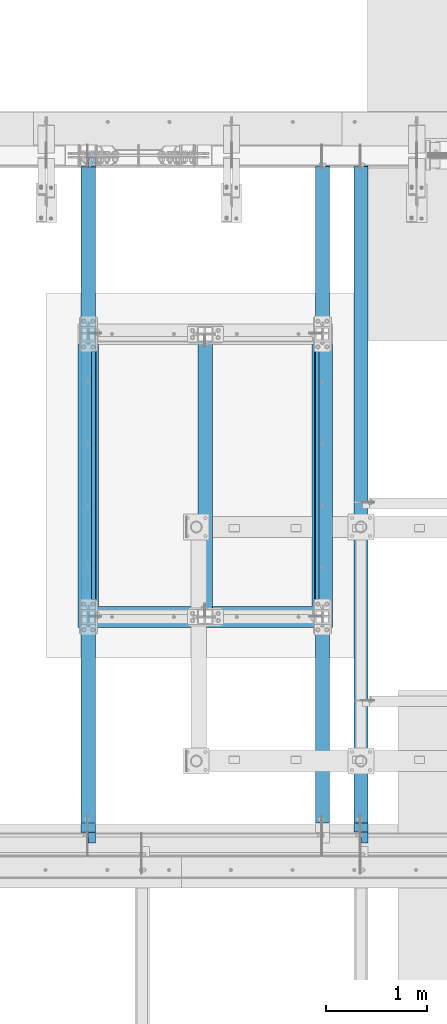
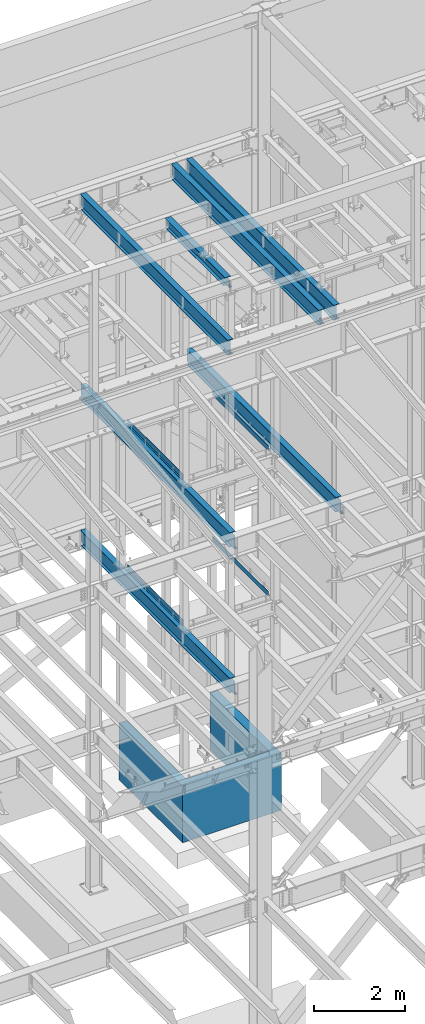
# One storey, part 772 of 1179: 12 beams, 10 elements without a shape of their own.
"""IFC2X3 building model written with IfcOpenShell, lengths in millimetres."""

from ifc_helpers import new_model, si_unit, frame, origin_with_axes, place, context, subcontext, project, spatial, faceted_brep, material, type_object, element, aggregate, save


model = new_model("IFC2X3")

# Units and contexts
model_context = context("Model", 3, precision=1e-05, world=origin_with_axes())
body_context = subcontext(model_context, "Body", "Model", "MODEL_VIEW")
ifc_project = project(units=[si_unit("LENGTHUNIT", "METRE", prefix="MILLI"), si_unit("AREAUNIT", "SQUARE_METRE"), si_unit("VOLUMEUNIT", "CUBIC_METRE"), si_unit("MASSUNIT", "GRAM", prefix="KILO"), si_unit("TIMEUNIT", "SECOND"), si_unit("PLANEANGLEUNIT", "RADIAN"), si_unit("SOLIDANGLEUNIT", "STERADIAN"), si_unit("THERMODYNAMICTEMPERATUREUNIT", "DEGREE_CELSIUS"), si_unit("LUMINOUSINTENSITYUNIT", "LUMEN")], contexts=[model_context])

# Site, building, storey
site_placement = place(None, origin_with_axes())
site = spatial("IfcSite", under=ifc_project, at=site_placement, CompositionType="ELEMENT")
building_placement = place(site_placement, origin_with_axes())
building = spatial("IfcBuilding", under=site, at=building_placement, Name="Undefined", CompositionType="ELEMENT")
storey_placement = place(building_placement, origin_with_axes())
storey = spatial("IfcBuildingStorey", under=building, at=storey_placement, Name="Undefined", CompositionType="ELEMENT", Elevation=0.0)

# Assembly, beam
assembly_1_placement = place(storey_placement, origin_with_axes())
assembly_1 = element("IfcElementAssembly", 1, at=assembly_1_placement, inside=storey, Name="BEAM", AssemblyPlace="NOTDEFINED", PredefinedType="RIGID_FRAME")
ifc_material_1 = material(Name="STEEL/A992")
beam_type_1 = type_object("IfcBeamType", Name="W10X22", PredefinedType="NOTDEFINED")
beam_1_placement = place(assembly_1_placement, frame((13030.2, 36639.5, 12990.5125), z_axis=(0.0, 0.0, 1.0), x_axis=(0.0, 1.0, 0.0)))
beam_1 = element("IfcBeam", 2, at=beam_1_placement, type_object=beam_type_1, material=ifc_material_1, Name="BEAM", ObjectType="W10X22", context=body_context, shape_type="Brep", body=[
    faceted_brep([(142.875, 3.37346071813408, -119.0625), (142.875, 3.37346071813408, -128.5875), (15.875, 3.37346071813408, -128.5875), (15.875, 3.17499999999927, -119.0625), (142.875001471613, 73.0249999999996, -119.0625), (142.875001471613, 73.0249999999996, -128.5875), (76.1999999999898, 3.17499999999927, 119.0625), (76.1999999999898, 73.0249999999996, 119.0625), (2717.8, 73.0249999999996, 119.0625), (2717.8, 3.17499999999927, 119.0625), (76.1999999999898, -73.0249999999996, 128.5875), (76.1999999999898, 73.0249999999996, 128.5875), (76.1999999999898, 3.17499999999927, 115.887499809265), (76.1999999999898, -3.17499999999927, 115.887499809265), (76.1999999999898, -3.17499999999927, 119.0625), (76.1999999999898, -73.0249999999996, 119.0625), (75.2332700773986, 3.17499999999927, 111.027420291219), (75.2332700773986, -3.17499999999927, 111.027420291219), (72.4802561769247, 3.17499999999927, 106.907243823065), (72.4802561769247, -3.17499999999927, 106.907243823065), (68.3600797087711, 3.17499999999927, 104.154229922588), (68.3600797087711, -3.17499999999927, 104.154229922588), (63.5000001907247, 3.17499999999927, 103.1875), (63.5000001907247, -3.17499999999927, 103.1875), (15.875, 3.17499999999927, 103.1875), (15.875, -3.17499999999927, 103.1875), (15.875, -3.17499999999927, -119.0625), (15.875, -73.0249999999996, -119.0625), (2778.125, -73.0249999999996, -119.0625), (2778.125, -3.17499999999927, -119.0625), (15.875, -73.0249999999996, -128.5875), (2778.125, -73.0249999999996, -128.5875), (2651.12499819296, 3.17499999999927, -119.0625), (2651.12499819296, 3.37346071813408, -128.5875), (2651.12499966458, 73.0249999999996, -128.5875), (2651.12499966458, 73.0249999999996, -119.0625), (2778.125, 3.17499999999927, -119.0625), (2778.125, 3.37346071813408, -128.5875), (2778.125, 3.17499999999927, 12.4375), (2778.125, 3.17499999999927, 103.1875), (2778.125, -3.17499999999927, 103.1875), (2725.63992029122, -3.17499999999927, 104.154229922588), (2721.51974382307, -3.17499999999927, 106.907243823065), (2718.76672992259, -3.17499999999927, 111.027420291219), (2717.8, -3.17499999999927, 115.887499809265), (2717.8, -3.17499999999927, 119.0625), (2730.49999980927, -3.17499999999927, 103.1875), (2717.8, -73.0249999999996, 119.0625), (2717.8, -73.0249999999996, 128.5875), (2717.8, 73.0249999999996, 128.5875), (2717.8, 3.17499999999927, 115.887499809265), (2718.76672992259, 3.17499999999927, 111.027420291219), (2721.51974382307, 3.17499999999927, 106.907243823065), (2725.63992029122, 3.17499999999927, 104.154229922588), (2730.49999980927, 3.17499999999927, 103.1875), (15.875, 3.17499999999927, 12.4375)], [[[0, 1, 2, 3]], [[4, 5, 1, 0]], [[6, 7, 8, 9]], [[10, 11, 7, 6, 12, 13, 14, 15]], [[13, 12, 16, 17]], [[17, 16, 18, 19]], [[19, 18, 20, 21]], [[21, 20, 22, 23]], [[23, 22, 24, 25]], [[26, 27, 28, 29]], [[27, 30, 31, 28]], [[32, 33, 34, 35]], [[36, 37, 33, 32]], [[38, 39, 40, 29, 28, 31, 37, 36]], [[41, 42, 43, 44, 45, 14, 13, 17, 19, 21, 23, 25, 26, 29, 40, 46]], [[15, 14, 45, 47]], [[10, 15, 47, 48]], [[11, 10, 48, 49]], [[7, 11, 49, 8]], [[48, 47, 45, 44, 50, 9, 8, 49]], [[43, 51, 50, 44]], [[42, 52, 51, 43]], [[41, 53, 52, 42]], [[46, 54, 53, 41]], [[40, 39, 54, 46]], [[38, 36, 32, 0, 3, 55, 24, 22, 20, 18, 16, 12, 6, 9, 50, 51, 52, 53, 54, 39]], [[30, 27, 26, 25, 24, 55, 3, 2]], [[34, 33, 37, 31, 30, 2, 1, 5]], [[35, 34, 5, 4]], [[32, 35, 4, 0]]]),
])
aggregate(assembly_1, [beam_1])

assembly_2_placement = place(storey_placement, origin_with_axes())
assembly_2 = element("IfcElementAssembly", 3, at=assembly_2_placement, inside=storey, Name="BEAM", AssemblyPlace="NOTDEFINED", PredefinedType="RIGID_FRAME")
ifc_material_2 = material(Name="STEEL/A36")
beam_type_2 = type_object("IfcBeamType", PredefinedType="NOTDEFINED")
beam_2_placement = place(assembly_2_placement, frame((14154.150030639, 38036.4994552154, 8016.875), z_axis=(0.0, -1.0, 0.0), x_axis=(-1.0, 0.0, 0.0)))
beam_2 = element("IfcBeam", 4, at=beam_2_placement, type_object=beam_type_2, material=ifc_material_2, Name="BENT_PLATE", context=body_context, shape_type="Brep", body=[
    faceted_brep([(-2.00088834390044e-10, -3.17500000000018, -1225.55), (2.05545802600682e-10, -3.17500000000018, 1225.55), (2.05545802600682e-10, 3.17500000000018, 1225.55), (-2.00088834390044e-10, 3.17500000000018, -1225.55), (44.4502379994137, 3.17500000000018, 1225.55), (44.4502379990063, 3.17500000000018, -1225.55000000001), (38.1002379990059, -3.17500000000018, -1225.55000000001), (38.1002379994134, -3.17500000000018, 1225.55), (44.4502379994137, -130.175006103521, 1225.55), (44.4502379990063, -130.175006103521, -1225.55000000001), (38.1002379994134, -130.175006103521, 1225.55), (38.1002379990059, -130.175006103521, -1225.55000000001)], [[[0, 1, 2, 3]], [[3, 2, 4, 5]], [[1, 0, 6, 7]], [[5, 4, 8, 9]], [[4, 2, 1, 7, 10, 8]], [[7, 6, 11, 10]], [[6, 0, 3, 5, 9, 11]], [[10, 11, 9, 8]]]),
])
aggregate(assembly_2, [beam_2])

assembly_3_placement = place(storey_placement, origin_with_axes())
assembly_3 = element("IfcElementAssembly", 5, at=assembly_3_placement, inside=storey, Name="BEAM", AssemblyPlace="NOTDEFINED", PredefinedType="RIGID_FRAME")
beam_3_placement = place(assembly_3_placement, frame((11906.2498572847, 38036.4995114133, 8016.875), z_axis=(0.0, -1.0, 0.0), x_axis=(1.0, 0.0, 0.0)))
beam_3 = element("IfcBeam", 6, at=beam_3_placement, type_object=beam_type_2, material=ifc_material_2, Name="BENT_PLATE", context=body_context, shape_type="Brep", body=[
    faceted_brep([(-2.00088834390044e-10, -3.17500000000018, -1225.55), (2.05545802600682e-10, -3.17500000000018, 1225.55), (2.05545802600682e-10, 3.17500000000018, 1225.55), (-2.00088834390044e-10, 3.17500000000018, -1225.55), (38.0999999996566, 3.17500000000018, 1225.55000000001), (38.1000000004224, 3.17500000000018, -1225.55), (44.4500000004227, -3.17500000000018, -1225.55), (44.4499999996569, -3.17500000000018, 1225.55000000001), (38.0999999996602, 130.175006103443, 1225.55000000001), (38.1000000004187, 130.175006103512, -1225.54999999999), (44.4499999996606, 130.175006103443, 1225.55000000002), (44.4500000004191, 130.175006103512, -1225.54999999999)], [[[0, 1, 2, 3]], [[3, 2, 4, 5]], [[1, 0, 6, 7]], [[5, 4, 8, 9]], [[4, 2, 1, 7, 10, 8]], [[7, 6, 11, 10]], [[6, 0, 3, 5, 9, 11]], [[10, 11, 9, 8]]]),
])

assembly_4_placement = place(storey_placement, origin_with_axes())
assembly_4 = element("IfcElementAssembly", 7, at=assembly_4_placement, inside=storey, Name="BEAM", AssemblyPlace="NOTDEFINED", PredefinedType="RIGID_FRAME")
beam_4_placement = place(assembly_4_placement, frame((14154.1501189205, 38036.499512207, 4105.275), z_axis=(0.0, -1.0, 0.0), x_axis=(-1.0, 0.0, 0.0)))
beam_4 = element("IfcBeam", 8, at=beam_4_placement, type_object=beam_type_2, material=ifc_material_2, Name="BENT_PLATE", context=body_context, shape_type="Brep", body=[
    faceted_brep([(-2.00088834390044e-10, -3.17500000000018, -1225.55), (2.05545802600682e-10, -3.17500000000018, 1225.55), (2.05545802600682e-10, 3.17500000000018, 1225.55), (-2.00088834390044e-10, 3.17500000000018, -1225.55), (44.4502379994137, 3.17500000000018, 1225.55), (44.4502379990063, 3.17500000000018, -1225.55000000001), (38.1002379990059, -3.17500000000018, -1225.55000000001), (38.1002379994134, -3.17500000000018, 1225.55), (44.4502379994137, -130.175006103521, 1225.55), (44.4502379990063, -130.175006103521, -1225.55000000001), (38.1002379994134, -130.175006103521, 1225.55), (38.1002379990059, -130.175006103521, -1225.55000000001)], [[[0, 1, 2, 3]], [[3, 2, 4, 5]], [[1, 0, 6, 7]], [[5, 4, 8, 9]], [[4, 2, 1, 7, 10, 8]], [[7, 6, 11, 10]], [[6, 0, 3, 5, 9, 11]], [[10, 11, 9, 8]]]),
])
aggregate(assembly_4, [beam_4])

assembly_5_placement = place(storey_placement, origin_with_axes())
assembly_5 = element("IfcElementAssembly", 9, at=assembly_5_placement, inside=storey, Name="BEAM", AssemblyPlace="NOTDEFINED", PredefinedType="RIGID_FRAME")
beam_5_placement = place(assembly_5_placement, frame((11906.2499455662, 38036.499512207, 4105.275), z_axis=(0.0, -1.0, 0.0), x_axis=(1.0, 0.0, 0.0)))
beam_5 = element("IfcBeam", 10, at=beam_5_placement, type_object=beam_type_2, material=ifc_material_2, Name="BENT_PLATE", context=body_context, shape_type="Brep", body=[
    faceted_brep([(-2.00088834390044e-10, -3.17500000000018, -1225.55), (2.05545802600682e-10, -3.17500000000018, 1225.55), (2.05545802600682e-10, 3.17500000000018, 1225.55), (-2.00088834390044e-10, 3.17500000000018, -1225.55), (38.0999999996566, 3.17500000000018, 1225.55000000001), (38.1000000004224, 3.17500000000018, -1225.55), (44.4500000004227, -3.17500000000018, -1225.55), (44.4499999996569, -3.17500000000018, 1225.55000000001), (38.0999999996602, 130.175006103443, 1225.55000000001), (38.1000000004187, 130.175006103512, -1225.54999999999), (44.4499999996606, 130.175006103443, 1225.55000000002), (44.4500000004191, 130.175006103512, -1225.54999999999)], [[[0, 1, 2, 3]], [[3, 2, 4, 5]], [[1, 0, 6, 7]], [[5, 4, 8, 9]], [[4, 2, 1, 7, 10, 8]], [[7, 6, 11, 10]], [[6, 0, 3, 5, 9, 11]], [[10, 11, 9, 8]]]),
])

assembly_6_placement = place(storey_placement, origin_with_axes())
assembly_6 = element("IfcElementAssembly", 11, at=assembly_6_placement, inside=storey, Name="BEAM", AssemblyPlace="NOTDEFINED", PredefinedType="RIGID_FRAME")
beam_type_3 = type_object("IfcBeamType", Name="W16X31", PredefinedType="NOTDEFINED")
beam_6_placement = place(assembly_6_placement, frame((14566.9, 34391.6, 12917.4875), z_axis=(0.0, 0.0, 1.0), x_axis=(0.0, 1.0, 0.0)))
beam_6 = element("IfcBeam", 12, at=beam_6_placement, type_object=beam_type_3, material=ifc_material_1, Name="BEAM", ObjectType="W16X31", context=body_context, shape_type="Brep", body=[
    faceted_brep([(212.724999999999, 69.8499999999985, -190.5), (212.724999999999, 3.17499999999927, -190.5), (6661.94375000001, 3.17499999999927, -190.5), (6661.94375000001, 69.8499999999985, -190.5), (212.724999999999, -3.17499999999927, -190.5), (212.724999999999, -69.8499999999985, -190.5), (6788.94375000001, -69.8499999999985, -190.5), (6788.94375000001, -3.17499999999927, -190.5), (212.724999999999, -69.8499999999985, -201.612499999999), (6788.94375000001, -69.8499999999985, -201.612499999999), (6788.94375000001, 3.17549991607666, -201.612499999999), (6788.94375000001, 3.17499999999927, -190.5), (6788.94375000001, 3.17499999999927, 163.512499999999), (6788.94375000001, -3.17499999999927, 163.512499999999), (6661.94375000001, 3.17549991607666, -201.612499999999), (212.724999999999, 69.8499999999985, -201.612499999999), (6661.94375000001, 69.8499999999985, -201.612499999999), (212.724999999999, -3.17499999999927, 190.5), (212.724999999999, -69.8499999999985, 190.5), (212.724999999999, -69.8499999999985, 201.612499999999), (212.724999999999, 69.8499999999985, 201.612499999999), (212.724999999999, 69.8499999999985, 190.5), (212.724999999999, 3.17499999999927, 190.5), (212.724999999999, 3.17499999999927, 162.664998864024), (212.724999999999, 3.17499999999927, -142.027500567505), (6696.86875000001, 69.8499999999985, 190.5), (6696.86875000001, 3.17499999999927, 190.5), (6696.86875000001, 3.17499999999927, 176.212499809264), (6697.8354799226, 3.17499999999927, 171.352420291218), (6700.58849382307, 3.17499999999927, 167.232243823064), (6704.70867029123, 3.17499999999927, 164.479229922586), (6709.56874980927, 3.17499999999927, 163.512499999999), (6697.8354799226, -3.17499999999927, 171.352420291218), (6696.86875000001, -3.17499999999927, 176.212499809264), (6700.58849382307, -3.17499999999927, 167.232243823064), (6704.70867029123, -3.17499999999927, 164.479229922586), (6709.56874980927, -3.17499999999927, 163.512499999999), (6696.86875000001, -3.17499999999927, 190.5), (6696.86875000001, -69.8499999999985, 190.5), (6696.86875000001, -69.8499999999985, 201.612499999999), (6696.86875000001, 69.8499999999985, 201.612499999999)], [[[0, 1, 2, 3]], [[4, 5, 6, 7]], [[5, 8, 9, 6]], [[7, 6, 9, 10, 11, 12, 13]], [[11, 10, 14, 2]], [[9, 8, 15, 16, 14, 10]], [[2, 14, 16, 3]], [[15, 0, 3, 16]], [[8, 5, 4, 17, 18, 19, 20, 21, 22, 23, 24, 1, 0, 15]], [[22, 21, 25, 26]], [[11, 2, 1, 24, 23, 22, 26, 27, 28, 29, 30, 31, 12]], [[32, 28, 27, 33]], [[34, 29, 28, 32]], [[35, 30, 29, 34]], [[36, 31, 30, 35]], [[13, 12, 31, 36]], [[35, 34, 32, 33, 37, 17, 4, 7, 13, 36]], [[18, 17, 37, 38]], [[19, 18, 38, 39]], [[20, 19, 39, 40]], [[21, 20, 40, 25]], [[39, 38, 37, 33, 27, 26, 25, 40]]]),
])
aggregate(assembly_6, [beam_6])

assembly_7_placement = place(storey_placement, origin_with_axes())
assembly_7 = element("IfcElementAssembly", 13, at=assembly_7_placement, inside=storey, Name="BEAM", AssemblyPlace="NOTDEFINED", PredefinedType="RIGID_FRAME")
beam_7_placement = place(assembly_7_placement, frame((14185.9, 34391.6, 12917.4875), z_axis=(0.0, 0.0, 1.0), x_axis=(0.0, 1.0, 0.0)))
beam_7 = element("IfcBeam", 14, at=beam_7_placement, type_object=beam_type_3, material=ifc_material_1, Name="BEAM", ObjectType="W16X31", context=body_context, shape_type="Brep", body=[
    faceted_brep([(212.724999999999, 69.8499999999985, -190.5), (212.724999999999, 3.17499999999927, -190.5), (6661.94375000001, 3.17499999999927, -190.5), (6661.94375000001, 69.8499999999985, -190.5), (212.724999999999, -3.17499999999927, -190.5), (212.724999999999, -69.8499999999985, -190.5), (6788.94375000001, -69.8499999999985, -190.5), (6788.94375000001, -3.17499999999927, -190.5), (212.724999999999, -69.8499999999985, -201.612499999999), (6788.94375000001, -69.8499999999985, -201.612499999999), (6788.94375000001, 3.17549991607666, -201.612499999999), (6788.94375000001, 3.17499999999927, -190.5), (6788.94375000001, 3.17499999999927, 163.512499999999), (6788.94375000001, -3.17499999999927, 163.512499999999), (6661.94375000001, 3.17549991607666, -201.612499999999), (212.724999999999, 69.8499999999985, -201.612499999999), (6661.94375000001, 69.8499999999985, -201.612499999999), (212.724999999999, -3.17499999999927, 190.5), (212.724999999999, -69.8499999999985, 190.5), (212.724999999999, -69.8499999999985, 201.612499999999), (212.724999999999, 69.8499999999985, 201.612499999999), (212.724999999999, 69.8499999999985, 190.5), (212.724999999999, 3.17499999999927, 190.5), (212.724999999999, 3.17499999999927, 162.664998864024), (212.724999999999, 3.17499999999927, -142.027500567505), (6696.86875000001, 69.8499999999985, 190.5), (6696.86875000001, 3.17499999999927, 190.5), (6696.86875000001, 3.17499999999927, 176.212499809264), (6697.8354799226, 3.17499999999927, 171.352420291218), (6700.58849382307, 3.17499999999927, 167.232243823064), (6704.70867029123, 3.17499999999927, 164.479229922586), (6709.56874980927, 3.17499999999927, 163.512499999999), (6697.8354799226, -3.17499999999927, 171.352420291218), (6696.86875000001, -3.17499999999927, 176.212499809264), (6700.58849382307, -3.17499999999927, 167.232243823064), (6704.70867029123, -3.17499999999927, 164.479229922586), (6709.56874980927, -3.17499999999927, 163.512499999999), (6696.86875000001, -3.17499999999927, 190.5), (6696.86875000001, -69.8499999999985, 190.5), (6696.86875000001, -69.8499999999985, 201.612499999999), (6696.86875000001, 69.8499999999985, 201.612499999999)], [[[0, 1, 2, 3]], [[4, 5, 6, 7]], [[5, 8, 9, 6]], [[7, 6, 9, 10, 11, 12, 13]], [[11, 10, 14, 2]], [[9, 8, 15, 16, 14, 10]], [[2, 14, 16, 3]], [[15, 0, 3, 16]], [[8, 5, 4, 17, 18, 19, 20, 21, 22, 23, 24, 1, 0, 15]], [[22, 21, 25, 26]], [[11, 2, 1, 24, 23, 22, 26, 27, 28, 29, 30, 31, 12]], [[32, 28, 27, 33]], [[34, 29, 28, 32]], [[35, 30, 29, 34]], [[36, 31, 30, 35]], [[13, 12, 31, 36]], [[35, 34, 32, 33, 37, 17, 4, 7, 13, 36]], [[18, 17, 37, 38]], [[19, 18, 38, 39]], [[20, 19, 39, 40]], [[21, 20, 40, 25]], [[39, 38, 37, 33, 27, 26, 25, 40]]]),
])
aggregate(assembly_7, [beam_7])

assembly_8_placement = place(storey_placement, origin_with_axes())
assembly_8 = element("IfcElementAssembly", 15, at=assembly_8_placement, inside=storey, Name="BEAM", AssemblyPlace="NOTDEFINED", PredefinedType="RIGID_FRAME")
beam_8_placement = place(assembly_8_placement, frame((11874.5, 34391.6, 12917.4875), z_axis=(0.0, 0.0, 1.0), x_axis=(0.0, 1.0, 0.0)))
beam_8 = element("IfcBeam", 16, at=beam_8_placement, type_object=beam_type_3, material=ifc_material_1, Name="BEAM", ObjectType="W16X31", context=body_context, shape_type="Brep", body=[
    faceted_brep([(212.724999999999, 69.8499999999985, -190.5), (212.724999999999, 3.17499999999927, -190.5), (6661.94375000001, 3.17499999999927, -190.5), (6661.94375000001, 69.8499999999985, -190.5), (212.724999999999, -3.17499999999927, -190.5), (212.724999999999, -69.8499999999985, -190.5), (6788.94375000001, -69.8499999999985, -190.5), (6788.94375000001, -3.17499999999927, -190.5), (212.724999999999, -69.8499999999985, -201.612499999999), (6788.94375000001, -69.8499999999985, -201.612499999999), (6788.94375000001, 3.17549991607666, -201.612499999999), (6788.94375000001, 3.17499999999927, -190.5), (6788.94375000001, 3.17499999999927, 163.512499999999), (6788.94375000001, -3.17499999999927, 163.512499999999), (6661.94375000001, 3.17549991607666, -201.612499999999), (212.724999999999, 69.8499999999985, -201.612499999999), (6661.94375000001, 69.8499999999985, -201.612499999999), (212.724999999999, -3.17499999999927, 190.5), (212.724999999999, -69.8499999999985, 190.5), (212.724999999999, -69.8499999999985, 201.612499999999), (212.724999999999, 69.8499999999985, 201.612499999999), (212.724999999999, 69.8499999999985, 190.5), (212.724999999999, 3.17499999999927, 190.5), (212.724999999999, 3.17499999999927, 162.664998864024), (212.724999999999, 3.17499999999927, -142.027500567505), (6696.86875000001, 69.8499999999985, 190.5), (6696.86875000001, 3.17499999999927, 190.5), (6696.86875000001, 3.17499999999927, 176.212499809264), (6697.8354799226, 3.17499999999927, 171.352420291218), (6700.58849382307, 3.17499999999927, 167.232243823064), (6704.70867029123, 3.17499999999927, 164.479229922586), (6709.56874980927, 3.17499999999927, 163.512499999999), (6697.8354799226, -3.17499999999927, 171.352420291218), (6696.86875000001, -3.17499999999927, 176.212499809264), (6700.58849382307, -3.17499999999927, 167.232243823064), (6704.70867029123, -3.17499999999927, 164.479229922586), (6709.56874980927, -3.17499999999927, 163.512499999999), (6696.86875000001, -3.17499999999927, 190.5), (6696.86875000001, -69.8499999999985, 190.5), (6696.86875000001, -69.8499999999985, 201.612499999999), (6696.86875000001, 69.8499999999985, 201.612499999999)], [[[0, 1, 2, 3]], [[4, 5, 6, 7]], [[5, 8, 9, 6]], [[7, 6, 9, 10, 11, 12, 13]], [[11, 10, 14, 2]], [[9, 8, 15, 16, 14, 10]], [[2, 14, 16, 3]], [[15, 0, 3, 16]], [[8, 5, 4, 17, 18, 19, 20, 21, 22, 23, 24, 1, 0, 15]], [[22, 21, 25, 26]], [[11, 2, 1, 24, 23, 22, 26, 27, 28, 29, 30, 31, 12]], [[32, 28, 27, 33]], [[34, 29, 28, 32]], [[35, 30, 29, 34]], [[36, 31, 30, 35]], [[13, 12, 31, 36]], [[35, 34, 32, 33, 37, 17, 4, 7, 13, 36]], [[18, 17, 37, 38]], [[19, 18, 38, 39]], [[20, 19, 39, 40]], [[21, 20, 40, 25]], [[39, 38, 37, 33, 27, 26, 25, 40]]]),
])
aggregate(assembly_8, [beam_8])

assembly_9_placement = place(storey_placement, origin_with_axes())
assembly_9 = element("IfcElementAssembly", 17, at=assembly_9_placement, inside=storey, Name="BEAM", AssemblyPlace="NOTDEFINED", PredefinedType="RIGID_FRAME")
beam_9_placement = place(assembly_9_placement, frame((14566.9, 34391.6, 7812.0875), z_axis=(0.0, 0.0, 1.0), x_axis=(0.0, 1.0, 0.0)))
beam_9 = element("IfcBeam", 18, at=beam_9_placement, type_object=beam_type_3, material=ifc_material_1, Name="BEAM", ObjectType="W16X31", context=body_context, shape_type="Brep", body=[
    faceted_brep([(112.712500190733, -3.17499999999927, 166.6875), (112.712500190733, 3.17496929493791, 166.6875), (17.4624999999942, 3.17499999999927, 166.6875), (17.4624999999942, -3.17499999999927, 166.6875), (117.57257970878, -3.17499999999927, 167.654229922588), (117.57257970878, 3.17496867180853, 167.654229922588), (121.692756176933, -3.17499999999927, 170.407243823066), (121.692756176933, 3.17496689728614, 170.407243823066), (124.445770077407, -3.17499999999927, 174.52742029122), (124.445770077407, 3.17496424152705, 174.52742029122), (125.412499999999, -3.17499999999927, 179.387499809265), (125.412499999999, 3.17496110884349, 179.387499809265), (125.412499999999, -69.8500000000004, 201.6125), (125.412499999999, 69.8500000000004, 201.6125), (125.412499999999, 69.8500000000004, 190.5), (125.412499999999, 3.17499999999927, 190.5), (125.412499999999, -3.17499999999927, 190.5), (125.412499999999, -69.8500000000004, 190.5), (6660.35625, 3.17499999999927, -190.5), (6660.35625, 69.8500000000004, -190.5), (144.462499999994, 69.8499999999985, -190.5), (144.462499999994, 3.17549991607666, -190.5), (17.4624999999942, -3.17499999999927, -190.5), (17.4624999999942, -69.8499999999985, -190.5), (6787.35625, -69.8500000000004, -190.5), (6787.35625, -3.17499999999927, -190.5), (17.4624999999942, -69.8499999999985, -201.6125), (6787.35625, -69.8500000000004, -201.6125), (6660.35625, 69.8500000000004, -201.6125), (6660.35625, 3.17549991607484, -201.6125), (6787.35625, 3.17549991607484, -201.6125), (17.4624999999942, 3.17549991607666, -201.6125), (144.462499999994, 3.17549991607666, -201.6125), (144.462499999994, 69.8499999999985, -201.6125), (17.4624999999942, 3.17499999999927, -190.5), (6787.35625, 3.17499999999927, -190.5), (6787.35625, 3.17499999999927, 157.1625), (6787.35625, -3.17499999999927, 157.1625), (6700.04374980927, 3.17499999999927, 157.1625), (6700.04374980927, -3.17499999999927, 157.1625), (6695.18367029123, 3.17499999999927, 158.129229922588), (6695.18367029123, -3.17499999999927, 158.129229922588), (6691.06349382307, 3.17499999999927, 160.882243823066), (6691.06349382307, -3.17499999999927, 160.882243823066), (6688.31047992259, 3.17499999999927, 165.00242029122), (6688.31047992259, -3.17499999999927, 165.00242029122), (6687.34375000001, 3.17499999999927, 169.862499809266), (6687.34375000001, -3.17499999999927, 169.862499809266), (6687.34375000001, -69.8500000000004, 201.6125), (6687.34375000001, -69.8500000000004, 190.5), (6687.34375000001, -3.17499999999927, 190.5), (6687.34375000001, 3.17499999999927, 190.5), (6687.34375000001, 69.8500000000004, 190.5), (6687.34375000001, 69.8500000000004, 201.6125)], [[[0, 1, 2, 3]], [[4, 5, 1, 0]], [[6, 7, 5, 4]], [[8, 9, 7, 6]], [[10, 11, 9, 8]], [[12, 13, 14, 15, 11, 10, 16, 17]], [[18, 19, 20, 21]], [[22, 23, 24, 25]], [[23, 26, 27, 24]], [[28, 29, 30, 27, 26, 31, 32, 33]], [[21, 32, 31, 34]], [[20, 33, 32, 21]], [[19, 28, 33, 20]], [[18, 29, 28, 19]], [[35, 30, 29, 18]], [[25, 24, 27, 30, 35, 36, 37]], [[37, 36, 38, 39]], [[39, 38, 40, 41]], [[41, 40, 42, 43]], [[43, 42, 44, 45]], [[45, 44, 46, 47]], [[48, 49, 50, 47, 46, 51, 52, 53]], [[49, 48, 12, 17]], [[50, 49, 17, 16]], [[8, 6, 4, 0, 3, 22, 25, 37, 39, 41, 43, 45, 47, 50, 16, 10]], [[34, 31, 26, 23, 22, 3, 2]], [[51, 46, 44, 42, 40, 38, 36, 35, 18, 21, 34, 2, 1, 5, 7, 9, 11, 15]], [[52, 51, 15, 14]], [[53, 52, 14, 13]], [[48, 53, 13, 12]]]),
])
aggregate(assembly_9, [beam_9])

# Beam
beam_10_placement = place(assembly_3_placement, frame((11874.5, 34391.6, 7812.0875), z_axis=(0.0, 0.0, 1.0), x_axis=(0.0, 1.0, 0.0)))
beam_10 = element("IfcBeam", 19, at=beam_10_placement, type_object=beam_type_3, material=ifc_material_1, Name="BEAM", ObjectType="W16X31", context=body_context, shape_type="Brep", body=[
    faceted_brep([(104.775000190733, -3.17499999999927, 166.6875), (104.775000190733, 3.17497120592088, 166.6875), (17.4624999999942, 3.17499999999927, 166.6875), (17.4624999999942, -3.17499999999927, 166.6875), (109.63507970878, -3.17499999999927, 167.654229922588), (109.63507970878, 3.17497058299341, 167.654229922588), (113.755256176933, -3.17499999999927, 170.407243823066), (113.755256176933, 3.17496880904946, 170.407243823066), (116.508270077407, -3.17499999999927, 174.52742029122), (116.508270077407, 3.17496615415439, 174.52742029122), (117.474999999999, -3.17499999999927, 179.387499809265), (117.474999999999, 3.17496302249128, 179.387499809265), (117.474999999999, -69.8499999999985, 201.6125), (117.474999999999, 69.8499999999985, 201.6125), (117.474999999999, 69.8499999999985, 190.5), (117.474999999999, 3.17499999999927, 190.5), (117.474999999999, -3.17499999999927, 190.5), (117.474999999999, -69.8499999999985, 190.5), (6660.35625, 3.17499999999927, -190.5), (6660.35625, 69.8500000000004, -190.5), (144.462499999994, 69.8499999999985, -190.5), (144.462499999994, 3.17549991607666, -190.5), (17.4624999999942, -3.17499999999927, -190.5), (17.4624999999942, -69.8499999999985, -190.5), (6787.35625, -69.8500000000004, -190.5), (6787.35625, -3.17499999999927, -190.5), (17.4624999999942, -69.8499999999985, -201.6125), (6787.35625, -69.8500000000004, -201.6125), (6660.35625, 69.8500000000004, -201.6125), (6660.35625, 3.17549991607484, -201.6125), (6787.35625, 3.17549991607484, -201.6125), (17.4624999999942, 3.17549991607666, -201.6125), (144.462499999994, 3.17549991607666, -201.6125), (144.462499999994, 69.8499999999985, -201.6125), (17.4624999999942, 3.17499999999927, -190.5), (6787.35625, 3.17499999999927, -190.5), (6787.35625, 3.17499999999927, 157.1625), (6787.35625, -3.17499999999927, 157.1625), (6700.04374980927, 3.17499999999927, 157.1625), (6700.04374980927, -3.17499999999927, 157.1625), (6695.18367029123, 3.17499999999927, 158.129229922588), (6695.18367029123, -3.17499999999927, 158.129229922588), (6691.06349382307, 3.17499999999927, 160.882243823066), (6691.06349382307, -3.17499999999927, 160.882243823066), (6688.31047992259, 3.17499999999927, 165.00242029122), (6688.31047992259, -3.17499999999927, 165.00242029122), (6687.34375000001, 3.17499999999927, 169.862499809266), (6687.34375000001, -3.17499999999927, 169.862499809266), (6687.34375000001, -69.8500000000004, 201.6125), (6687.34375000001, -69.8500000000004, 190.5), (6687.34375000001, -3.17499999999927, 190.5), (6687.34375000001, 3.17499999999927, 190.5), (6687.34375000001, 69.8500000000004, 190.5), (6687.34375000001, 69.8500000000004, 201.6125)], [[[0, 1, 2, 3]], [[4, 5, 1, 0]], [[6, 7, 5, 4]], [[8, 9, 7, 6]], [[10, 11, 9, 8]], [[12, 13, 14, 15, 11, 10, 16, 17]], [[18, 19, 20, 21]], [[22, 23, 24, 25]], [[23, 26, 27, 24]], [[28, 29, 30, 27, 26, 31, 32, 33]], [[21, 32, 31, 34]], [[20, 33, 32, 21]], [[19, 28, 33, 20]], [[18, 29, 28, 19]], [[35, 30, 29, 18]], [[25, 24, 27, 30, 35, 36, 37]], [[37, 36, 38, 39]], [[39, 38, 40, 41]], [[41, 40, 42, 43]], [[43, 42, 44, 45]], [[45, 44, 46, 47]], [[48, 49, 50, 47, 46, 51, 52, 53]], [[49, 48, 12, 17]], [[50, 49, 17, 16]], [[8, 6, 4, 0, 3, 22, 25, 37, 39, 41, 43, 45, 47, 50, 16, 10]], [[34, 31, 26, 23, 22, 3, 2]], [[51, 46, 44, 42, 40, 38, 36, 35, 18, 21, 34, 2, 1, 5, 7, 9, 11, 15]], [[52, 51, 15, 14]], [[53, 52, 14, 13]], [[48, 53, 13, 12]]]),
])

aggregate(assembly_3, [beam_3, beam_10])

beam_11_placement = place(assembly_5_placement, frame((11874.5001686096, 34391.6, 3900.4875), z_axis=(0.0, 0.0, 1.0), x_axis=(0.0, 1.0, 0.0)))
beam_11 = element("IfcBeam", 20, at=beam_11_placement, type_object=beam_type_3, material=ifc_material_1, Name="BEAM", ObjectType="W16X31", context=body_context, shape_type="Brep", body=[
    faceted_brep([(18.2562500000006, -69.8499999999985, -190.5), (18.2562500000006, -69.8499999999985, -201.612499999999), (6787.35625, -69.8500000000004, -201.6125), (6787.35625, -69.8500000000004, -190.5), (18.2562500793938, 3.17558455032122, -201.6125), (145.256250079394, 3.17558137532069, -201.6125), (145.256250000001, 69.8499999999985, -201.612499999999), (6660.35625, 69.8500000000004, -201.6125), (6660.3562500794, 3.17555155085756, -201.6125), (6787.35625, 3.17549991607484, -201.6125), (145.256250079394, 3.17558137532069, -190.5), (18.2562500000006, 3.17500000000291, -190.5), (145.256250000001, 69.8499999999985, -190.5), (6660.35625, 3.17499999999927, -190.5), (6660.35625, 69.8500000000004, -190.5), (6787.35625, 3.17499999999927, -190.5), (6787.35625, -3.17499999999927, -190.5), (6787.35625007939, 3.17500000129257, 163.512499999999), (6787.35624992065, -3.17499999870779, 163.512499999999), (18.2562500000006, -3.17500000000291, -190.5), (18.2562514952835, -3.17499999999927, 169.8625), (18.2562514952835, 3.17499999999927, 169.8625), (113.506251936145, -3.17499999997744, 169.8625), (113.506251936145, 3.17496422017757, 169.8625), (118.366331454192, -3.17499999997926, 170.829229922588), (118.366331454192, 3.17496349569046, 170.829229922588), (122.486507922345, -3.17499999997744, 173.582243823066), (122.486507922345, 3.17496143253265, 173.582243823066), (125.239521822827, -3.17499999997563, 177.70242029122), (125.239521822819, 3.17495834479632, 177.70242029122), (126.206251745411, -3.17499999997744, 182.562499809265), (126.206251745411, 3.1749547025629, 182.562499809265), (126.206251745432, -69.8499999999767, 201.6125), (126.206251745396, 69.850000000024, 201.6125), (126.206251745396, 69.850000000024, 190.5), (126.206251745418, 3.17500000002292, 190.5), (126.206251745411, -3.17499999997744, 190.5), (126.206251745432, -69.8499999999767, 190.5), (6687.34375000001, 69.8500000000004, 190.5), (6687.34375000001, 3.17499999999927, 190.5), (6687.3437517463, 3.17494718995658, 176.212499809265), (6688.31048166887, 3.17500000127438, 171.352420291219), (6691.06349556935, 3.17500000127438, 167.232243823065), (6695.18367203751, 3.1750000012762, 164.479229922587), (6700.04375155555, 3.1750000012762, 163.512499999999), (6688.31048166887, -3.17499999872598, 171.352420291219), (6687.34375174629, -3.17499999872598, 176.212499809265), (6691.06349556935, -3.17499999872598, 167.232243823065), (6695.18367203751, -3.17499999872416, 164.479229922587), (6700.04375155555, -3.17499999872416, 163.512499999999), (6687.34375000001, -3.17499999999927, 190.5), (6687.34375000001, -69.8500000000004, 190.5), (6687.34375000001, -69.8500000000004, 201.6125), (6687.34375000001, 69.8500000000004, 201.6125)], [[[0, 1, 2, 3]], [[2, 1, 4, 5, 6, 7, 8, 9]], [[10, 5, 4, 11]], [[12, 6, 5, 10]], [[13, 14, 12, 10]], [[14, 7, 6, 12]], [[13, 8, 7, 14]], [[15, 9, 8, 13]], [[16, 3, 2, 9, 15, 17, 18]], [[19, 0, 3, 16]], [[11, 4, 1, 0, 19, 20, 21]], [[22, 23, 21, 20]], [[24, 25, 23, 22]], [[26, 27, 25, 24]], [[28, 29, 27, 26]], [[30, 31, 29, 28]], [[32, 33, 34, 35, 31, 30, 36, 37]], [[38, 39, 35, 34]], [[15, 13, 10, 11, 21, 23, 25, 27, 29, 31, 35, 39, 40, 41, 42, 43, 44, 17]], [[45, 41, 40, 46]], [[47, 42, 41, 45]], [[48, 43, 42, 47]], [[49, 44, 43, 48]], [[18, 17, 44, 49]], [[28, 26, 24, 22, 20, 19, 16, 18, 49, 48, 47, 45, 46, 50, 36, 30]], [[50, 51, 37, 36]], [[51, 52, 32, 37]], [[52, 53, 33, 32]], [[53, 38, 34, 33]], [[52, 51, 50, 46, 40, 39, 38, 53]]]),
])

aggregate(assembly_5, [beam_5, beam_11])

# Assembly, beam
assembly_10_placement = place(storey_placement, origin_with_axes())
assembly_10 = element("IfcElementAssembly", 21, at=assembly_10_placement, inside=storey, Name="BEAM", AssemblyPlace="NOTDEFINED", PredefinedType="REINFORCEMENT_UNIT")
ifc_material_3 = material(Name="CONCRETE/5000")
beam_type_4 = type_object("IfcBeamType", PredefinedType="NOTDEFINED")
beam_12_placement = place(assembly_10_placement, frame((11874.5, 39331.9, -762.0), z_axis=(0.0, 0.0, 1.0), x_axis=(0.0, -1.0, 0.0)))
beam_12 = element("IfcBeam", 22, at=beam_12_placement, type_object=beam_type_4, material=ifc_material_3, Name="BEAM", context=body_context, shape_type="Brep", body=[
    faceted_brep([(0.0, -101.599999999999, -762.0), (0.0, -101.599999999999, 762.0), (0.0, 101.599999999999, 762.0), (0.0, 101.599999999999, -762.0), (2590.79990234375, 101.599999999999, 762.0), (2590.79990234375, 101.599999999999, -762.0), (2793.99990234375, -101.599999999999, -762.0), (2793.99990234375, -101.599999999999, 762.0), (2590.79990234375, 2209.79990234375, 762.0), (2590.79990234375, 2209.79990234375, -762.0), (2793.99990234375, 2412.99990234375, -762.0), (2793.99990234375, 2412.99990234375, 762.0), (-1.52587745105848e-06, 2209.79990234375, 762.0), (-1.52587745105848e-06, 2209.79990234375, -762.0), (-1.52587745105848e-06, 2412.99990234375, 762.0), (-1.52587745105848e-06, 2412.99990234375, -762.0)], [[[0, 1, 2, 3]], [[3, 2, 4, 5]], [[1, 0, 6, 7]], [[5, 4, 8, 9]], [[7, 6, 10, 11]], [[9, 8, 12, 13]], [[8, 4, 2, 1, 7, 11, 14, 12]], [[11, 10, 15, 14]], [[10, 6, 0, 3, 5, 9, 13, 15]], [[14, 15, 13, 12]]]),
])
aggregate(assembly_10, [beam_12])

save(model, "model.ifc")
